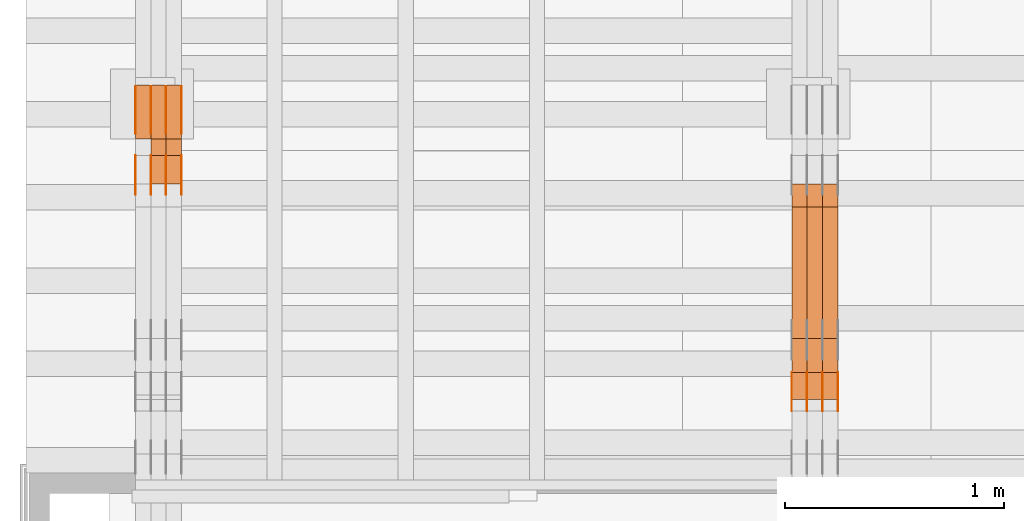
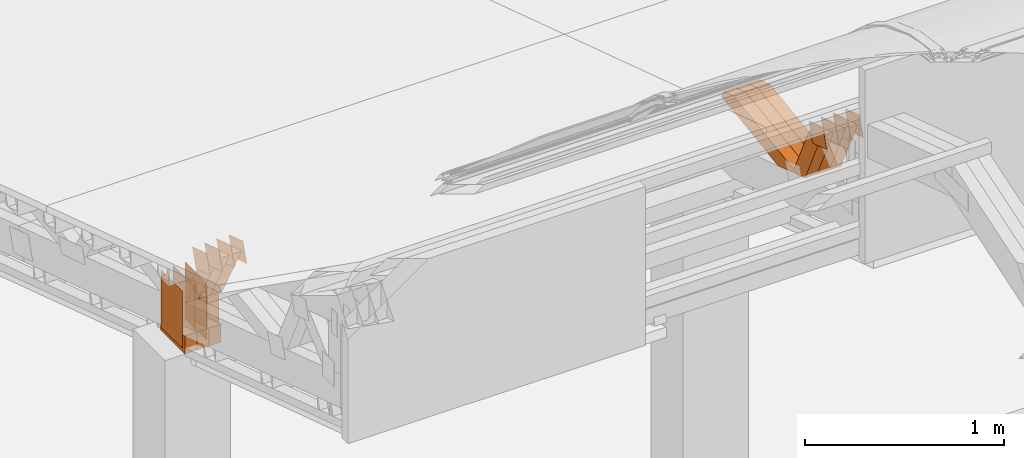
# One storey, part 84 of 385: 29 proxies.
"""IFC2X3 building model written with IfcOpenShell, lengths in millimetres."""

from ifc_helpers import new_model, entity, si_unit, converted_unit, derived_unit, direction, frame, origin, origin_2d_with_axis, place, context, subcontext, project, spatial, polyline, rectangle, outline, extrude, source, transform, mapped, material, type_object, type_shapes, element, save


model = new_model("IFC2X3")

# Units and contexts
model_context = context("Model", 3, precision=0.01, world=origin(), true_north=direction((6.12303176911189e-17, 1.0)))
body_context = subcontext(model_context, "Body", "Model", "MODEL_VIEW")
ifc_project = project(units=[si_unit("LENGTHUNIT", "METRE", prefix="MILLI"), si_unit("AREAUNIT", "SQUARE_METRE"), si_unit("VOLUMEUNIT", "CUBIC_METRE"), converted_unit("PLANEANGLEUNIT", "DEGREE", entity("IfcRatioMeasure", 0.0174532925199433), si_unit("PLANEANGLEUNIT", "RADIAN"), dimensions=[0, 0, 0, 0, 0, 0, 0]), si_unit("MASSUNIT", "GRAM", prefix="KILO"), derived_unit("MASSDENSITYUNIT", [(si_unit("MASSUNIT", "GRAM", prefix="KILO"), 1), (si_unit("LENGTHUNIT", "METRE"), -3)]), si_unit("TIMEUNIT", "SECOND"), si_unit("FREQUENCYUNIT", "HERTZ"), si_unit("THERMODYNAMICTEMPERATUREUNIT", "DEGREE_CELSIUS"), derived_unit("THERMALTRANSMITTANCEUNIT", [(si_unit("MASSUNIT", "GRAM", prefix="KILO"), 1), (si_unit("THERMODYNAMICTEMPERATUREUNIT", "KELVIN"), -1), (si_unit("TIMEUNIT", "SECOND"), -3)]), derived_unit("VOLUMETRICFLOWRATEUNIT", [(si_unit("LENGTHUNIT", "METRE"), 3), (si_unit("TIMEUNIT", "SECOND"), -1)]), si_unit("ELECTRICCURRENTUNIT", "AMPERE"), si_unit("ELECTRICVOLTAGEUNIT", "VOLT"), si_unit("POWERUNIT", "WATT"), si_unit("FORCEUNIT", "NEWTON", prefix="KILO"), si_unit("ILLUMINANCEUNIT", "LUX"), si_unit("LUMINOUSFLUXUNIT", "LUMEN"), si_unit("LUMINOUSINTENSITYUNIT", "CANDELA"), derived_unit("USERDEFINED", [(si_unit("MASSUNIT", "GRAM", prefix="KILO"), -1), (si_unit("LENGTHUNIT", "METRE"), -2), (si_unit("TIMEUNIT", "SECOND"), 3), (si_unit("LUMINOUSFLUXUNIT", "LUMEN"), 1)]), derived_unit("LINEARVELOCITYUNIT", [(si_unit("LENGTHUNIT", "METRE"), 1), (si_unit("TIMEUNIT", "SECOND"), -1)]), si_unit("PRESSUREUNIT", "PASCAL"), derived_unit("USERDEFINED", [(si_unit("LENGTHUNIT", "METRE"), -2), (si_unit("MASSUNIT", "GRAM", prefix="KILO"), 1), (si_unit("TIMEUNIT", "SECOND"), -2)])], contexts=[model_context])

# Site, building, storey
site_placement = place(None, origin())
site = spatial("IfcSite", under=ifc_project, at=site_placement, CompositionType="ELEMENT")
building_placement = place(site_placement, origin())
building = spatial("IfcBuilding", under=site, at=building_placement, CompositionType="ELEMENT")
storey_placement = place(building_placement, origin())
storey = spatial("IfcBuildingStorey", under=building, at=storey_placement, Name="Default", CompositionType="ELEMENT", Elevation=0.0)

# Proxies
ifc_material_1 = material(Name="IfcSurfaceStyle #62862")
building_element_proxy_type_1 = type_object("IfcBuildingElementProxyType", PredefinedType="NOTDEFINED", material=ifc_material_1)
shared_shape_1 = source(origin(), body_context, "Body", "SweptSolid", [
    extrude(outline(polyline([(-75.0003249421702, -60.0000773549573), (75.0003398116874, -60.0000773549573), (75.0003249421711, 60.0000773549573), (-75.0003398116883, 60.0000773549573), (-75.0003249421702, -60.0000773549573)])), frame((75.0003398116874, 60.0000773549573, 0.0), z_axis=(0.0, 0.0, 1.0), x_axis=(-1.0, 0.0, 0.0)), (0.0, 0.0, 1.0), 1.3),
])
type_shapes(building_element_proxy_type_1, [shared_shape_1])
proxy_1_placement = place(building_placement, frame((3386.29999999999, 16117.0849050545, 3705.49074668796), z_axis=(-1.0, 0.0, 0.0), x_axis=(0.0, -0.951056516295154, 0.309016994374948)))
element("IfcBuildingElementProxy", 1, at=proxy_1_placement, inside=storey, type_object=building_element_proxy_type_1, material=ifc_material_1, context=body_context, shape_type="MappedRepresentation", body=[
    mapped(shared_shape_1, transform((0.0, 0.0, 0.0), scale=1.0)),
])
ifc_material_2 = material(Name="IfcSurfaceStyle #62805")
building_element_proxy_type_2 = type_object("IfcBuildingElementProxyType", PredefinedType="NOTDEFINED", material=ifc_material_2)
shared_shape_2 = source(origin(), body_context, "Body", "SweptSolid", [
    extrude(outline(polyline([(-75.0003249421702, -60.0000773549573), (75.0003398116874, -60.0000773549573), (75.0003249421711, 60.0000773549573), (-75.0003398116883, 60.0000773549573), (-75.0003249421702, -60.0000773549573)])), frame((75.0003398116874, 60.0000773549573, 0.0), z_axis=(0.0, 0.0, 1.0), x_axis=(-1.0, 0.0, 0.0)), (0.0, 0.0, 1.0), 1.3),
])
type_shapes(building_element_proxy_type_2, [shared_shape_2])
proxy_2_placement = place(building_placement, frame((3315.0, 16117.0849050545, 3705.49074668796), z_axis=(-1.0, 0.0, 0.0), x_axis=(0.0, -0.951056516295154, 0.309016994374948)))
element("IfcBuildingElementProxy", 2, at=proxy_2_placement, inside=storey, type_object=building_element_proxy_type_2, material=ifc_material_2, context=body_context, shape_type="MappedRepresentation", body=[
    mapped(shared_shape_2, transform((0.0, 0.0, 0.0), scale=1.0)),
])
ifc_material_3 = material(Name="IfcSurfaceStyle #62748")
building_element_proxy_type_3 = type_object("IfcBuildingElementProxyType", PredefinedType="NOTDEFINED", material=ifc_material_3)
shared_shape_3 = source(origin(), body_context, "Body", "SweptSolid", [
    extrude(outline(polyline([(-75.0003249421702, -60.0000773549573), (75.0003398116874, -60.0000773549573), (75.0003249421711, 60.0000773549573), (-75.0003398116883, 60.0000773549573), (-75.0003249421702, -60.0000773549573)])), frame((75.0003398116874, 60.0000773549573, 0.0), z_axis=(0.0, 0.0, 1.0), x_axis=(-1.0, 0.0, 0.0)), (0.0, 0.0, 1.0), 1.3),
])
type_shapes(building_element_proxy_type_3, [shared_shape_3])
proxy_3_placement = place(building_placement, frame((3316.29999999999, 16117.0849050545, 3705.49074668796), z_axis=(-1.0, 0.0, 0.0), x_axis=(0.0, -0.951056516295154, 0.309016994374948)))
element("IfcBuildingElementProxy", 3, at=proxy_3_placement, inside=storey, type_object=building_element_proxy_type_3, material=ifc_material_3, context=body_context, shape_type="MappedRepresentation", body=[
    mapped(shared_shape_3, transform((0.0, 0.0, 0.0), scale=1.0)),
])
ifc_material_4 = material(Name="IfcSurfaceStyle #62691")
building_element_proxy_type_4 = type_object("IfcBuildingElementProxyType", PredefinedType="NOTDEFINED", material=ifc_material_4)
shared_shape_4 = source(origin(), body_context, "Body", "SweptSolid", [
    extrude(outline(polyline([(-75.0003249421702, -60.0000773549573), (75.0003398116874, -60.0000773549573), (75.0003249421711, 60.0000773549573), (-75.0003398116883, 60.0000773549573), (-75.0003249421702, -60.0000773549573)])), frame((75.0003398116874, 60.0000773549573, 0.0), z_axis=(0.0, 0.0, 1.0), x_axis=(-1.0, 0.0, 0.0)), (0.0, 0.0, 1.0), 1.29999999999999),
])
type_shapes(building_element_proxy_type_4, [shared_shape_4])
proxy_4_placement = place(building_placement, frame((3245.0, 16117.0849050545, 3705.49074668796), z_axis=(-1.0, 0.0, 0.0), x_axis=(0.0, -0.951056516295154, 0.309016994374948)))
element("IfcBuildingElementProxy", 4, at=proxy_4_placement, inside=storey, type_object=building_element_proxy_type_4, material=ifc_material_4, context=body_context, shape_type="MappedRepresentation", body=[
    mapped(shared_shape_4, transform((0.0, 0.0, 0.0), scale=1.0)),
])
ifc_material_5 = material(Name="IfcSurfaceStyle #62634")
building_element_proxy_type_5 = type_object("IfcBuildingElementProxyType", PredefinedType="NOTDEFINED", material=ifc_material_5)
shared_shape_5 = source(origin(), body_context, "Body", "SweptSolid", [
    extrude(outline(polyline([(-75.0003249421702, -60.0000773549573), (75.0003398116874, -60.0000773549573), (75.0003249421711, 60.0000773549573), (-75.0003398116883, 60.0000773549573), (-75.0003249421702, -60.0000773549573)])), frame((75.0003398116874, 60.0000773549573, 0.0), z_axis=(0.0, 0.0, 1.0), x_axis=(-1.0, 0.0, 0.0)), (0.0, 0.0, 1.0), 1.29999999999999),
])
type_shapes(building_element_proxy_type_5, [shared_shape_5])
proxy_5_placement = place(building_placement, frame((3246.29999999999, 16117.0849050545, 3705.49074668796), z_axis=(-1.0, 0.0, 0.0), x_axis=(0.0, -0.951056516295154, 0.309016994374948)))
element("IfcBuildingElementProxy", 5, at=proxy_5_placement, inside=storey, type_object=building_element_proxy_type_5, material=ifc_material_5, context=body_context, shape_type="MappedRepresentation", body=[
    mapped(shared_shape_5, transform((0.0, 0.0, 0.0), scale=1.0)),
])
ifc_material_6 = material(Name="IfcSurfaceStyle #62577")
building_element_proxy_type_6 = type_object("IfcBuildingElementProxyType", PredefinedType="NOTDEFINED", material=ifc_material_6)
shared_shape_6 = source(origin(), body_context, "Body", "SweptSolid", [
    extrude(outline(polyline([(-75.0003249421702, -60.0000773549573), (75.0003398116874, -60.0000773549573), (75.0003249421711, 60.0000773549573), (-75.0003398116883, 60.0000773549573), (-75.0003249421702, -60.0000773549573)])), frame((75.0003398116874, 60.0000773549573, 0.0), z_axis=(0.0, 0.0, 1.0), x_axis=(-1.0, 0.0, 0.0)), (0.0, 0.0, 1.0), 1.29999999999999),
])
type_shapes(building_element_proxy_type_6, [shared_shape_6])
proxy_6_placement = place(building_placement, frame((3175.0, 16117.0849050545, 3705.49074668796), z_axis=(-1.0, 0.0, 0.0), x_axis=(0.0, -0.951056516295154, 0.309016994374948)))
element("IfcBuildingElementProxy", 6, at=proxy_6_placement, inside=storey, type_object=building_element_proxy_type_6, material=ifc_material_6, context=body_context, shape_type="MappedRepresentation", body=[
    mapped(shared_shape_6, transform((0.0, 0.0, 0.0), scale=1.0)),
])
ifc_material_7 = material(Name="IfcSurfaceStyle #52242")
building_element_proxy_type_7 = type_object("IfcBuildingElementProxyType", Name="T1-W44 52240", PredefinedType="NOTDEFINED", material=ifc_material_7)
shared_shape_7 = source(origin(), body_context, "Body", "SweptSolid", [
    extrude(outline(polyline([(-184.551057772692, -47.4997984945814), (177.527112951531, -47.4997984945814), (162.630077773546, -0.000452497529500495), (118.068221667048, 47.5000247433462), (-273.674354619433, 47.5000247433462), (-184.551057772692, -47.4997984945814)])), frame((177.527112951531, 47.5002721629815, 0.0), z_axis=(0.0, 0.0, 1.0), x_axis=(-1.0, 0.0, 0.0)), (0.0, 0.0, 1.0), 70.0),
])
type_shapes(building_element_proxy_type_7, [shared_shape_7])
proxy_7_placement = place(building_placement, frame((3385.0, 16220.4899216004, 3388.98238154171), z_axis=(-1.0, 0.0, 0.0), x_axis=(0.0, -0.425335045192995, 0.905035965766374)))
element("IfcBuildingElementProxy", 7, at=proxy_7_placement, inside=storey, type_object=building_element_proxy_type_7, material=ifc_material_7, Name="T1-W44", context=body_context, shape_type="MappedRepresentation", body=[
    mapped(shared_shape_7, transform((0.0, 0.0, 0.0), scale=1.0)),
])
ifc_material_8 = material(Name="IfcSurfaceStyle #52176")
building_element_proxy_type_8 = type_object("IfcBuildingElementProxyType", Name="T1-W44 52174", PredefinedType="NOTDEFINED", material=ifc_material_8)
shared_shape_8 = source(origin(), body_context, "Body", "SweptSolid", [
    extrude(outline(polyline([(-184.551057772692, -47.4997984945814), (177.527112951531, -47.4997984945814), (162.630077773546, -0.000452497529500495), (118.068221667048, 47.5000247433462), (-273.674354619433, 47.5000247433462), (-184.551057772692, -47.4997984945814)])), frame((177.527112951531, 47.5002721629815, 0.0), z_axis=(0.0, 0.0, 1.0), x_axis=(-1.0, 0.0, 0.0)), (0.0, 0.0, 1.0), 70.0),
])
type_shapes(building_element_proxy_type_8, [shared_shape_8])
proxy_8_placement = place(building_placement, frame((3315.0, 16220.4899216004, 3388.98238154171), z_axis=(-1.0, 0.0, 0.0), x_axis=(0.0, -0.425335045192995, 0.905035965766374)))
element("IfcBuildingElementProxy", 8, at=proxy_8_placement, inside=storey, type_object=building_element_proxy_type_8, material=ifc_material_8, Name="T1-W44", context=body_context, shape_type="MappedRepresentation", body=[
    mapped(shared_shape_8, transform((0.0, 0.0, 0.0), scale=1.0)),
])
ifc_material_9 = material(Name="IfcSurfaceStyle #52110")
building_element_proxy_type_9 = type_object("IfcBuildingElementProxyType", Name="T1-W44 52108", PredefinedType="NOTDEFINED", material=ifc_material_9)
shared_shape_9 = source(origin(), body_context, "Body", "SweptSolid", [
    extrude(outline(polyline([(-184.551057772692, -47.4997984945814), (177.527112951531, -47.4997984945814), (162.630077773546, -0.000452497529500495), (118.068221667048, 47.5000247433462), (-273.674354619433, 47.5000247433462), (-184.551057772692, -47.4997984945814)])), frame((177.527112951531, 47.5002721629815, 0.0), z_axis=(0.0, 0.0, 1.0), x_axis=(-1.0, 0.0, 0.0)), (0.0, 0.0, 1.0), 70.0),
])
type_shapes(building_element_proxy_type_9, [shared_shape_9])
proxy_9_placement = place(building_placement, frame((3245.0, 16220.4899216004, 3388.98238154171), z_axis=(-1.0, 0.0, 0.0), x_axis=(0.0, -0.425335045192995, 0.905035965766374)))
element("IfcBuildingElementProxy", 9, at=proxy_9_placement, inside=storey, type_object=building_element_proxy_type_9, material=ifc_material_9, Name="T1-W44", context=body_context, shape_type="MappedRepresentation", body=[
    mapped(shared_shape_9, transform((0.0, 0.0, 0.0), scale=1.0)),
])
ifc_material_10 = material(Name="IfcSurfaceStyle #51846")
building_element_proxy_type_10 = type_object("IfcBuildingElementProxyType", Name="T1-W8 51844", PredefinedType="NOTDEFINED", material=ifc_material_10)
shared_shape_10 = source(origin(), body_context, "Body", "SweptSolid", [
    extrude(outline(polyline([(-476.725263324644, -47.5001051695965), (180.672765845439, -47.5001051695965), (279.11020091716, -1.03605560390907e-06), (296.793624402619, 47.5001056876243), (-279.851327840575, 47.5001056876243), (-476.725263324644, -47.5001051695965)])), frame((296.793624402619, 47.5001056876243, 0.0), z_axis=(0.0, 0.0, 1.0), x_axis=(-1.0, 0.0, 0.0)), (0.0, 0.0, 1.0), 70.0),
])
type_shapes(building_element_proxy_type_10, [shared_shape_10])
proxy_10_placement = place(building_placement, frame((3385.0, 17036.40625, 3432.97192382813), z_axis=(-1.0, 0.0, 0.0), x_axis=(0.0, -0.990844046556832, -0.135011389900564)))
element("IfcBuildingElementProxy", 10, at=proxy_10_placement, inside=storey, type_object=building_element_proxy_type_10, material=ifc_material_10, Name="T1-W8", context=body_context, shape_type="MappedRepresentation", body=[
    mapped(shared_shape_10, transform((0.0, 0.0, 0.0), scale=1.0)),
])
ifc_material_11 = material(Name="IfcSurfaceStyle #51780")
building_element_proxy_type_11 = type_object("IfcBuildingElementProxyType", Name="T1-W8 51778", PredefinedType="NOTDEFINED", material=ifc_material_11)
shared_shape_11 = source(origin(), body_context, "Body", "SweptSolid", [
    extrude(outline(polyline([(-476.725263324644, -47.5001051695965), (180.672765845439, -47.5001051695965), (279.11020091716, -1.03605560390907e-06), (296.793624402619, 47.5001056876243), (-279.851327840575, 47.5001056876243), (-476.725263324644, -47.5001051695965)])), frame((296.793624402619, 47.5001056876243, 0.0), z_axis=(0.0, 0.0, 1.0), x_axis=(-1.0, 0.0, 0.0)), (0.0, 0.0, 1.0), 70.0),
])
type_shapes(building_element_proxy_type_11, [shared_shape_11])
proxy_11_placement = place(building_placement, frame((3315.0, 17036.40625, 3432.97192382813), z_axis=(-1.0, 0.0, 0.0), x_axis=(0.0, -0.990844046556832, -0.135011389900564)))
element("IfcBuildingElementProxy", 11, at=proxy_11_placement, inside=storey, type_object=building_element_proxy_type_11, material=ifc_material_11, Name="T1-W8", context=body_context, shape_type="MappedRepresentation", body=[
    mapped(shared_shape_11, transform((0.0, 0.0, 0.0), scale=1.0)),
])
ifc_material_12 = material(Name="IfcSurfaceStyle #51714")
building_element_proxy_type_12 = type_object("IfcBuildingElementProxyType", Name="T1-W8 51712", PredefinedType="NOTDEFINED", material=ifc_material_12)
shared_shape_12 = source(origin(), body_context, "Body", "SweptSolid", [
    extrude(outline(polyline([(-476.725263324644, -47.5001051695965), (180.672765845439, -47.5001051695965), (279.11020091716, -1.03605560390907e-06), (296.793624402619, 47.5001056876243), (-279.851327840575, 47.5001056876243), (-476.725263324644, -47.5001051695965)])), frame((296.793624402619, 47.5001056876243, 0.0), z_axis=(0.0, 0.0, 1.0), x_axis=(-1.0, 0.0, 0.0)), (0.0, 0.0, 1.0), 70.0),
])
type_shapes(building_element_proxy_type_12, [shared_shape_12])
proxy_12_placement = place(building_placement, frame((3245.0, 17036.40625, 3432.97192382813), z_axis=(-1.0, 0.0, 0.0), x_axis=(0.0, -0.990844046556832, -0.135011389900564)))
element("IfcBuildingElementProxy", 12, at=proxy_12_placement, inside=storey, type_object=building_element_proxy_type_12, material=ifc_material_12, Name="T1-W8", context=body_context, shape_type="MappedRepresentation", body=[
    mapped(shared_shape_12, transform((0.0, 0.0, 0.0), scale=1.0)),
])
ifc_material_13 = material(Name="IfcSurfaceStyle #30482")
building_element_proxy_type_13 = type_object("IfcBuildingElementProxyType", PredefinedType="NOTDEFINED", material=ifc_material_13)
shared_shape_13 = source(origin(), body_context, "Body", "SweptSolid", [
    extrude(rectangle(XDim=350.0, YDim=215.999999999984, at=origin_2d_with_axis()), frame((175.0, 108.0, 0.0), z_axis=(0.0, 0.0, 1.0), x_axis=(-1.0, 0.0, 0.0)), (0.0, 0.0, 1.0), 1.29999999999999),
])
type_shapes(building_element_proxy_type_13, [shared_shape_13])
proxy_13_placement = place(building_placement, frame((386.299999999986, 17459.2939453125, 3165.36425781251), z_axis=(-1.0, 0.0, 0.0), x_axis=(0.0, 0.0, -1.0)))
element("IfcBuildingElementProxy", 13, at=proxy_13_placement, inside=storey, type_object=building_element_proxy_type_13, material=ifc_material_13, context=body_context, shape_type="MappedRepresentation", body=[
    mapped(shared_shape_13, transform((0.0, 0.0, 0.0), scale=1.0)),
])
ifc_material_14 = material(Name="IfcSurfaceStyle #30425")
building_element_proxy_type_14 = type_object("IfcBuildingElementProxyType", PredefinedType="NOTDEFINED", material=ifc_material_14)
shared_shape_14 = source(origin(), body_context, "Body", "SweptSolid", [
    extrude(rectangle(XDim=350.0, YDim=215.999999999984, at=origin_2d_with_axis()), frame((175.0, 108.0, 0.0), z_axis=(0.0, 0.0, 1.0), x_axis=(-1.0, 0.0, 0.0)), (0.0, 0.0, 1.0), 1.29999999999999),
])
type_shapes(building_element_proxy_type_14, [shared_shape_14])
proxy_14_placement = place(building_placement, frame((315.0, 17459.2939453125, 3165.36425781251), z_axis=(-1.0, 0.0, 0.0), x_axis=(0.0, 0.0, -1.0)))
element("IfcBuildingElementProxy", 14, at=proxy_14_placement, inside=storey, type_object=building_element_proxy_type_14, material=ifc_material_14, context=body_context, shape_type="MappedRepresentation", body=[
    mapped(shared_shape_14, transform((0.0, 0.0, 0.0), scale=1.0)),
])
ifc_material_15 = material(Name="IfcSurfaceStyle #30368")
building_element_proxy_type_15 = type_object("IfcBuildingElementProxyType", PredefinedType="NOTDEFINED", material=ifc_material_15)
shared_shape_15 = source(origin(), body_context, "Body", "SweptSolid", [
    extrude(rectangle(XDim=350.0, YDim=215.999999999984, at=origin_2d_with_axis()), frame((175.0, 108.0, 0.0), z_axis=(0.0, 0.0, 1.0), x_axis=(-1.0, 0.0, 0.0)), (0.0, 0.0, 1.0), 1.29999999999999),
])
type_shapes(building_element_proxy_type_15, [shared_shape_15])
proxy_15_placement = place(building_placement, frame((316.299999999986, 17459.2939453125, 3165.36425781251), z_axis=(-1.0, 0.0, 0.0), x_axis=(0.0, 0.0, -1.0)))
element("IfcBuildingElementProxy", 15, at=proxy_15_placement, inside=storey, type_object=building_element_proxy_type_15, material=ifc_material_15, context=body_context, shape_type="MappedRepresentation", body=[
    mapped(shared_shape_15, transform((0.0, 0.0, 0.0), scale=1.0)),
])
ifc_material_16 = material(Name="IfcSurfaceStyle #30311")
building_element_proxy_type_16 = type_object("IfcBuildingElementProxyType", PredefinedType="NOTDEFINED", material=ifc_material_16)
shared_shape_16 = source(origin(), body_context, "Body", "SweptSolid", [
    extrude(rectangle(XDim=350.0, YDim=215.999999999984, at=origin_2d_with_axis()), frame((175.0, 108.0, 0.0), z_axis=(0.0, 0.0, 1.0), x_axis=(-1.0, 0.0, 0.0)), (0.0, 0.0, 1.0), 1.29999999999998),
])
type_shapes(building_element_proxy_type_16, [shared_shape_16])
proxy_16_placement = place(building_placement, frame((245.0, 17459.2939453125, 3165.36425781251), z_axis=(-1.0, 0.0, 0.0), x_axis=(0.0, 0.0, -1.0)))
element("IfcBuildingElementProxy", 16, at=proxy_16_placement, inside=storey, type_object=building_element_proxy_type_16, material=ifc_material_16, context=body_context, shape_type="MappedRepresentation", body=[
    mapped(shared_shape_16, transform((0.0, 0.0, 0.0), scale=1.0)),
])
ifc_material_17 = material(Name="IfcSurfaceStyle #30254")
building_element_proxy_type_17 = type_object("IfcBuildingElementProxyType", PredefinedType="NOTDEFINED", material=ifc_material_17)
shared_shape_17 = source(origin(), body_context, "Body", "SweptSolid", [
    extrude(rectangle(XDim=350.0, YDim=215.999999999984, at=origin_2d_with_axis()), frame((175.0, 108.0, 0.0), z_axis=(0.0, 0.0, 1.0), x_axis=(-1.0, 0.0, 0.0)), (0.0, 0.0, 1.0), 1.29999999999998),
])
type_shapes(building_element_proxy_type_17, [shared_shape_17])
proxy_17_placement = place(building_placement, frame((246.299999999986, 17459.2939453125, 3165.36425781251), z_axis=(-1.0, 0.0, 0.0), x_axis=(0.0, 0.0, -1.0)))
element("IfcBuildingElementProxy", 17, at=proxy_17_placement, inside=storey, type_object=building_element_proxy_type_17, material=ifc_material_17, context=body_context, shape_type="MappedRepresentation", body=[
    mapped(shared_shape_17, transform((0.0, 0.0, 0.0), scale=1.0)),
])
ifc_material_18 = material(Name="IfcSurfaceStyle #30197")
building_element_proxy_type_18 = type_object("IfcBuildingElementProxyType", PredefinedType="NOTDEFINED", material=ifc_material_18)
shared_shape_18 = source(origin(), body_context, "Body", "SweptSolid", [
    extrude(rectangle(XDim=350.0, YDim=215.999999999984, at=origin_2d_with_axis()), frame((175.0, 108.0, 0.0), z_axis=(0.0, 0.0, 1.0), x_axis=(-1.0, 0.0, 0.0)), (0.0, 0.0, 1.0), 1.29999999999998),
])
type_shapes(building_element_proxy_type_18, [shared_shape_18])
proxy_18_placement = place(building_placement, frame((175.0, 17459.2939453125, 3165.36425781251), z_axis=(-1.0, 0.0, 0.0), x_axis=(0.0, 0.0, -1.0)))
element("IfcBuildingElementProxy", 18, at=proxy_18_placement, inside=storey, type_object=building_element_proxy_type_18, material=ifc_material_18, context=body_context, shape_type="MappedRepresentation", body=[
    mapped(shared_shape_18, transform((0.0, 0.0, 0.0), scale=1.0)),
])
ifc_material_19 = material(Name="IfcSurfaceStyle #27062")
building_element_proxy_type_19 = type_object("IfcBuildingElementProxyType", PredefinedType="NOTDEFINED", material=ifc_material_19)
shared_shape_19 = source(origin(), body_context, "Body", "SweptSolid", [
    extrude(outline(polyline([(-74.9998605591058, -59.9999264677524), (74.999875428623, -59.9999264677524), (74.9998605591068, 59.9999264677524), (-74.9998754286239, 59.9999264677524), (-74.9998605591058, -59.9999264677524)])), frame((75.0002460484325, 60.0000016373508, 0.0), z_axis=(0.0, 0.0, 1.0), x_axis=(-1.0, 0.0, 0.0)), (0.0, 0.0, 1.0), 1.3),
])
type_shapes(building_element_proxy_type_19, [shared_shape_19])
proxy_19_placement = place(building_placement, frame((386.299999999986, 17107.0599369346, 3383.82825001787), z_axis=(-1.0, 0.0, 0.0), x_axis=(0.0, -0.951056516295154, 0.309016994374948)))
element("IfcBuildingElementProxy", 19, at=proxy_19_placement, inside=storey, type_object=building_element_proxy_type_19, material=ifc_material_19, context=body_context, shape_type="MappedRepresentation", body=[
    mapped(shared_shape_19, transform((0.0, 0.0, 0.0), scale=1.0)),
])
ifc_material_20 = material(Name="IfcSurfaceStyle #27005")
building_element_proxy_type_20 = type_object("IfcBuildingElementProxyType", PredefinedType="NOTDEFINED", material=ifc_material_20)
shared_shape_20 = source(origin(), body_context, "Body", "SweptSolid", [
    extrude(outline(polyline([(-74.9998605591058, -59.9999264677524), (74.999875428623, -59.9999264677524), (74.9998605591068, 59.9999264677524), (-74.9998754286239, 59.9999264677524), (-74.9998605591058, -59.9999264677524)])), frame((75.0002460484325, 60.0000016373508, 0.0), z_axis=(0.0, 0.0, 1.0), x_axis=(-1.0, 0.0, 0.0)), (0.0, 0.0, 1.0), 1.3),
])
type_shapes(building_element_proxy_type_20, [shared_shape_20])
proxy_20_placement = place(building_placement, frame((315.0, 17107.0599369346, 3383.82825001787), z_axis=(-1.0, 0.0, 0.0), x_axis=(0.0, -0.951056516295154, 0.309016994374948)))
element("IfcBuildingElementProxy", 20, at=proxy_20_placement, inside=storey, type_object=building_element_proxy_type_20, material=ifc_material_20, context=body_context, shape_type="MappedRepresentation", body=[
    mapped(shared_shape_20, transform((0.0, 0.0, 0.0), scale=1.0)),
])
ifc_material_21 = material(Name="IfcSurfaceStyle #26948")
building_element_proxy_type_21 = type_object("IfcBuildingElementProxyType", PredefinedType="NOTDEFINED", material=ifc_material_21)
shared_shape_21 = source(origin(), body_context, "Body", "SweptSolid", [
    extrude(outline(polyline([(-74.9998605591058, -59.9999264677524), (74.999875428623, -59.9999264677524), (74.9998605591068, 59.9999264677524), (-74.9998754286239, 59.9999264677524), (-74.9998605591058, -59.9999264677524)])), frame((75.0002460484325, 60.0000016373508, 0.0), z_axis=(0.0, 0.0, 1.0), x_axis=(-1.0, 0.0, 0.0)), (0.0, 0.0, 1.0), 1.3),
])
type_shapes(building_element_proxy_type_21, [shared_shape_21])
proxy_21_placement = place(building_placement, frame((316.299999999986, 17107.0599369346, 3383.82825001787), z_axis=(-1.0, 0.0, 0.0), x_axis=(0.0, -0.951056516295154, 0.309016994374948)))
element("IfcBuildingElementProxy", 21, at=proxy_21_placement, inside=storey, type_object=building_element_proxy_type_21, material=ifc_material_21, context=body_context, shape_type="MappedRepresentation", body=[
    mapped(shared_shape_21, transform((0.0, 0.0, 0.0), scale=1.0)),
])
ifc_material_22 = material(Name="IfcSurfaceStyle #26891")
building_element_proxy_type_22 = type_object("IfcBuildingElementProxyType", PredefinedType="NOTDEFINED", material=ifc_material_22)
shared_shape_22 = source(origin(), body_context, "Body", "SweptSolid", [
    extrude(outline(polyline([(-74.9998605591058, -59.9999264677524), (74.999875428623, -59.9999264677524), (74.9998605591068, 59.9999264677524), (-74.9998754286239, 59.9999264677524), (-74.9998605591058, -59.9999264677524)])), frame((75.0002460484325, 60.0000016373508, 0.0), z_axis=(0.0, 0.0, 1.0), x_axis=(-1.0, 0.0, 0.0)), (0.0, 0.0, 1.0), 1.29999999999999),
])
type_shapes(building_element_proxy_type_22, [shared_shape_22])
proxy_22_placement = place(building_placement, frame((245.0, 17107.0599369346, 3383.82825001787), z_axis=(-1.0, 0.0, 0.0), x_axis=(0.0, -0.951056516295154, 0.309016994374948)))
element("IfcBuildingElementProxy", 22, at=proxy_22_placement, inside=storey, type_object=building_element_proxy_type_22, material=ifc_material_22, context=body_context, shape_type="MappedRepresentation", body=[
    mapped(shared_shape_22, transform((0.0, 0.0, 0.0), scale=1.0)),
])
ifc_material_23 = material(Name="IfcSurfaceStyle #26834")
building_element_proxy_type_23 = type_object("IfcBuildingElementProxyType", PredefinedType="NOTDEFINED", material=ifc_material_23)
shared_shape_23 = source(origin(), body_context, "Body", "SweptSolid", [
    extrude(outline(polyline([(-74.9998605591058, -59.9999264677524), (74.999875428623, -59.9999264677524), (74.9998605591068, 59.9999264677524), (-74.9998754286239, 59.9999264677524), (-74.9998605591058, -59.9999264677524)])), frame((75.0002460484325, 60.0000016373508, 0.0), z_axis=(0.0, 0.0, 1.0), x_axis=(-1.0, 0.0, 0.0)), (0.0, 0.0, 1.0), 1.29999999999999),
])
type_shapes(building_element_proxy_type_23, [shared_shape_23])
proxy_23_placement = place(building_placement, frame((246.299999999986, 17107.0599369346, 3383.82825001787), z_axis=(-1.0, 0.0, 0.0), x_axis=(0.0, -0.951056516295154, 0.309016994374948)))
element("IfcBuildingElementProxy", 23, at=proxy_23_placement, inside=storey, type_object=building_element_proxy_type_23, material=ifc_material_23, context=body_context, shape_type="MappedRepresentation", body=[
    mapped(shared_shape_23, transform((0.0, 0.0, 0.0), scale=1.0)),
])
ifc_material_24 = material(Name="IfcSurfaceStyle #26777")
building_element_proxy_type_24 = type_object("IfcBuildingElementProxyType", PredefinedType="NOTDEFINED", material=ifc_material_24)
shared_shape_24 = source(origin(), body_context, "Body", "SweptSolid", [
    extrude(outline(polyline([(-74.9998605591058, -59.9999264677524), (74.999875428623, -59.9999264677524), (74.9998605591068, 59.9999264677524), (-74.9998754286239, 59.9999264677524), (-74.9998605591058, -59.9999264677524)])), frame((75.0002460484325, 60.0000016373508, 0.0), z_axis=(0.0, 0.0, 1.0), x_axis=(-1.0, 0.0, 0.0)), (0.0, 0.0, 1.0), 1.29999999999999),
])
type_shapes(building_element_proxy_type_24, [shared_shape_24])
proxy_24_placement = place(building_placement, frame((175.0, 17107.0599369346, 3383.82825001787), z_axis=(-1.0, 0.0, 0.0), x_axis=(0.0, -0.951056516295154, 0.309016994374948)))
element("IfcBuildingElementProxy", 24, at=proxy_24_placement, inside=storey, type_object=building_element_proxy_type_24, material=ifc_material_24, context=body_context, shape_type="MappedRepresentation", body=[
    mapped(shared_shape_24, transform((0.0, 0.0, 0.0), scale=1.0)),
])
ifc_material_25 = material(Name="IfcSurfaceStyle #18773")
building_element_proxy_type_25 = type_object("IfcBuildingElementProxyType", Name="T1-E1 18771", PredefinedType="NOTDEFINED", material=ifc_material_25)
shared_shape_25 = source(origin(), body_context, "Body", "SweptSolid", [
    extrude(outline(polyline([(4.4675903320374, -122.500000000001), (35.3350219726624, -122.500000000001), (35.3350219726501, 122.500000000001), (-75.1376342773499, 122.500000000001), (4.4675903320374, -122.500000000001)])), frame((35.3350219726624, 122.50000005215, 0.0), z_axis=(0.0, 0.0, 1.0), x_axis=(-1.0, 0.0, 0.0)), (0.0, 0.0, 1.0), 70.0),
])
type_shapes(building_element_proxy_type_25, [shared_shape_25])
proxy_25_placement = place(building_placement, frame((385.0, 17220.0, 2794.30932617186), z_axis=(-1.0, 0.0, 0.0), x_axis=(0.0, 0.0, 1.0)))
element("IfcBuildingElementProxy", 25, at=proxy_25_placement, inside=storey, type_object=building_element_proxy_type_25, material=ifc_material_25, Name="T1-E1", context=body_context, shape_type="MappedRepresentation", body=[
    mapped(shared_shape_25, transform((0.0, 0.0, 0.0), scale=1.0)),
])
ifc_material_26 = material(Name="IfcSurfaceStyle #18716")
building_element_proxy_type_26 = type_object("IfcBuildingElementProxyType", Name="T1-E1 18714", PredefinedType="NOTDEFINED", material=ifc_material_26)
shared_shape_26 = source(origin(), body_context, "Body", "SweptSolid", [
    extrude(outline(polyline([(4.4675903320374, -122.500000000001), (35.3350219726624, -122.500000000001), (35.3350219726501, 122.500000000001), (-75.1376342773499, 122.500000000001), (4.4675903320374, -122.500000000001)])), frame((35.3350219726624, 122.50000005215, 0.0), z_axis=(0.0, 0.0, 1.0), x_axis=(-1.0, 0.0, 0.0)), (0.0, 0.0, 1.0), 70.0),
])
type_shapes(building_element_proxy_type_26, [shared_shape_26])
proxy_26_placement = place(building_placement, frame((315.0, 17220.0, 2794.30932617186), z_axis=(-1.0, 0.0, 0.0), x_axis=(0.0, 0.0, 1.0)))
element("IfcBuildingElementProxy", 26, at=proxy_26_placement, inside=storey, type_object=building_element_proxy_type_26, material=ifc_material_26, Name="T1-E1", context=body_context, shape_type="MappedRepresentation", body=[
    mapped(shared_shape_26, transform((0.0, 0.0, 0.0), scale=1.0)),
])
ifc_material_27 = material(Name="IfcSurfaceStyle #18659")
building_element_proxy_type_27 = type_object("IfcBuildingElementProxyType", Name="T1-E1 18657", PredefinedType="NOTDEFINED", material=ifc_material_27)
shared_shape_27 = source(origin(), body_context, "Body", "SweptSolid", [
    extrude(outline(polyline([(4.4675903320374, -122.500000000001), (35.3350219726624, -122.500000000001), (35.3350219726501, 122.500000000001), (-75.1376342773499, 122.500000000001), (4.4675903320374, -122.500000000001)])), frame((35.3350219726624, 122.50000005215, 0.0), z_axis=(0.0, 0.0, 1.0), x_axis=(-1.0, 0.0, 0.0)), (0.0, 0.0, 1.0), 70.0),
])
type_shapes(building_element_proxy_type_27, [shared_shape_27])
proxy_27_placement = place(building_placement, frame((245.0, 17220.0, 2794.30932617186), z_axis=(-1.0, 0.0, 0.0), x_axis=(0.0, 0.0, 1.0)))
element("IfcBuildingElementProxy", 27, at=proxy_27_placement, inside=storey, type_object=building_element_proxy_type_27, material=ifc_material_27, Name="T1-E1", context=body_context, shape_type="MappedRepresentation", body=[
    mapped(shared_shape_27, transform((0.0, 0.0, 0.0), scale=1.0)),
])
ifc_material_28 = material(Name="IfcSurfaceStyle #17018")
building_element_proxy_type_28 = type_object("IfcBuildingElementProxyType", Name="T1-W39 17016", PredefinedType="NOTDEFINED", material=ifc_material_28)
shared_shape_28 = source(origin(), body_context, "Body", "SweptSolid", [
    extrude(outline(polyline([(-191.519946663886, -47.499928106579), (188.32936223763, -47.499928106579), (171.597440144109, 0.000249483340993841), (122.102882529753, 47.4998033649085), (-290.509738247605, 47.4998033649085), (-191.519946663886, -47.499928106579)])), frame((188.329593252001, 47.499957247623, 0.0), z_axis=(0.0, 0.0, 1.0), x_axis=(-1.0, 0.0, 0.0)), (0.0, 0.0, 1.0), 70.0),
])
type_shapes(building_element_proxy_type_28, [shared_shape_28])
proxy_28_placement = place(building_placement, frame((385.0, 17238.5876916597, 3055.56121424762), z_axis=(-1.0, 0.0, 0.0), x_axis=(0.0, -0.472216932390777, 0.881482370080902)))
element("IfcBuildingElementProxy", 28, at=proxy_28_placement, inside=storey, type_object=building_element_proxy_type_28, material=ifc_material_28, Name="T1-W39", context=body_context, shape_type="MappedRepresentation", body=[
    mapped(shared_shape_28, transform((0.0, 0.0, 0.0), scale=1.0)),
])
ifc_material_29 = material(Name="IfcSurfaceStyle #16952")
building_element_proxy_type_29 = type_object("IfcBuildingElementProxyType", Name="T1-W39 16950", PredefinedType="NOTDEFINED", material=ifc_material_29)
shared_shape_29 = source(origin(), body_context, "Body", "SweptSolid", [
    extrude(outline(polyline([(-191.519946663886, -47.499928106579), (188.32936223763, -47.499928106579), (171.597440144109, 0.000249483340993841), (122.102882529753, 47.4998033649085), (-290.509738247605, 47.4998033649085), (-191.519946663886, -47.499928106579)])), frame((188.329593252001, 47.499957247623, 0.0), z_axis=(0.0, 0.0, 1.0), x_axis=(-1.0, 0.0, 0.0)), (0.0, 0.0, 1.0), 70.0),
])
type_shapes(building_element_proxy_type_29, [shared_shape_29])
proxy_29_placement = place(building_placement, frame((315.0, 17238.5876916597, 3055.56121424762), z_axis=(-1.0, 0.0, 0.0), x_axis=(0.0, -0.472216932390777, 0.881482370080902)))
element("IfcBuildingElementProxy", 29, at=proxy_29_placement, inside=storey, type_object=building_element_proxy_type_29, material=ifc_material_29, Name="T1-W39", context=body_context, shape_type="MappedRepresentation", body=[
    mapped(shared_shape_29, transform((0.0, 0.0, 0.0), scale=1.0)),
])

save(model, "model.ifc")
